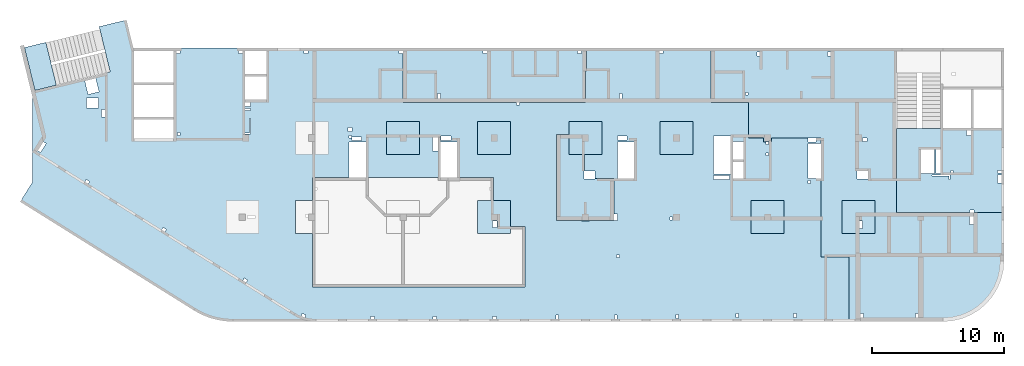
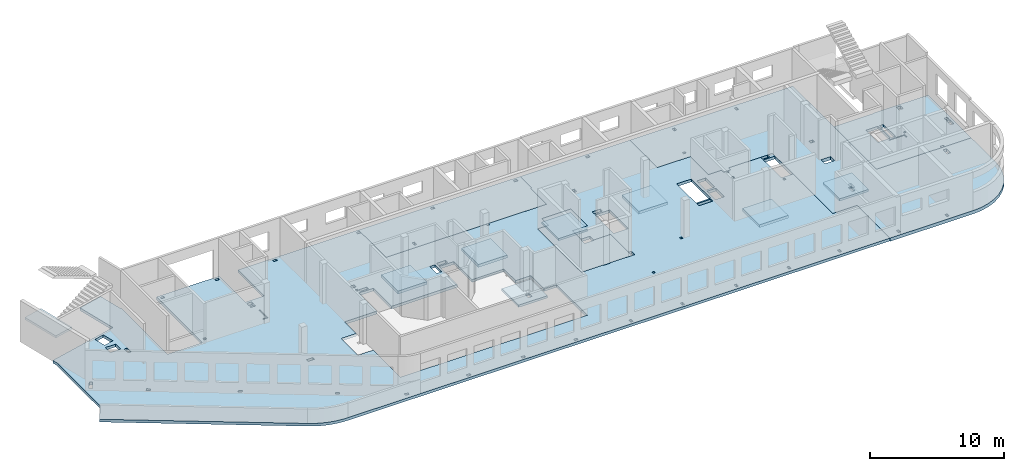
# One storey, part 2 of 10: 13 slabs.
"""IFC4 building model written with IfcOpenShell, lengths in millimetres."""

from ifc_helpers import new_model, entity, si_unit, converted_unit, derived_unit, direction, frame, origin, place, context, subcontext, project, spatial, indexed_curve, outline, extrude, material, type_object, element, save


model = new_model("IFC4")

# Units and contexts
model_context = context("Model", 3, precision=0.01, world=origin(), true_north=direction((6.12303176911189e-17, 1.0)))
plan_context = context("Plan", 3, precision=0.01, world=origin(), true_north=direction((6.12303176911189e-17, 1.0)))
body_context = subcontext(model_context, "Body", "Model", "MODEL_VIEW")
ifc_project = project(units=[si_unit("LENGTHUNIT", "METRE", prefix="MILLI"), si_unit("AREAUNIT", "SQUARE_METRE"), si_unit("VOLUMEUNIT", "CUBIC_METRE"), converted_unit("PLANEANGLEUNIT", "DEGREE", entity("IfcRatioMeasure", 0.0174532925199433), si_unit("PLANEANGLEUNIT", "RADIAN"), dimensions=[0, 0, 0, 0, 0, 0, 0]), si_unit("MASSUNIT", "GRAM", prefix="KILO"), derived_unit("MASSDENSITYUNIT", [(si_unit("MASSUNIT", "GRAM", prefix="KILO"), 1), (si_unit("LENGTHUNIT", "METRE"), -3)]), derived_unit("MOMENTOFINERTIAUNIT", [(si_unit("LENGTHUNIT", "METRE"), 4)]), si_unit("TIMEUNIT", "SECOND"), si_unit("FREQUENCYUNIT", "HERTZ"), si_unit("THERMODYNAMICTEMPERATUREUNIT", "DEGREE_CELSIUS"), derived_unit("THERMALTRANSMITTANCEUNIT", [(si_unit("MASSUNIT", "GRAM", prefix="KILO"), 1), (si_unit("THERMODYNAMICTEMPERATUREUNIT", "KELVIN"), -1), (si_unit("TIMEUNIT", "SECOND"), -3)]), derived_unit("VOLUMETRICFLOWRATEUNIT", [(si_unit("LENGTHUNIT", "METRE"), 3), (si_unit("TIMEUNIT", "SECOND"), -1)]), derived_unit("MASSFLOWRATEUNIT", [(si_unit("MASSUNIT", "GRAM", prefix="KILO"), 1), (si_unit("TIMEUNIT", "SECOND"), -1)]), derived_unit("ROTATIONALFREQUENCYUNIT", [(si_unit("TIMEUNIT", "SECOND"), -1)]), si_unit("ELECTRICCURRENTUNIT", "AMPERE"), si_unit("ELECTRICVOLTAGEUNIT", "VOLT"), si_unit("POWERUNIT", "WATT"), si_unit("FORCEUNIT", "NEWTON", prefix="KILO"), si_unit("ILLUMINANCEUNIT", "LUX"), si_unit("LUMINOUSFLUXUNIT", "LUMEN"), si_unit("LUMINOUSINTENSITYUNIT", "CANDELA"), derived_unit("USERDEFINED", [(si_unit("MASSUNIT", "GRAM", prefix="KILO"), -1), (si_unit("LENGTHUNIT", "METRE"), -2), (si_unit("TIMEUNIT", "SECOND"), 3), (si_unit("LUMINOUSFLUXUNIT", "LUMEN"), 1)]), derived_unit("LINEARVELOCITYUNIT", [(si_unit("LENGTHUNIT", "METRE"), 1), (si_unit("TIMEUNIT", "SECOND"), -1)]), si_unit("PRESSUREUNIT", "PASCAL"), derived_unit("USERDEFINED", [(si_unit("LENGTHUNIT", "METRE"), -2), (si_unit("MASSUNIT", "GRAM", prefix="KILO"), 1), (si_unit("TIMEUNIT", "SECOND"), -2)]), derived_unit("LINEARFORCEUNIT", [(si_unit("MASSUNIT", "GRAM", prefix="KILO"), 1), (si_unit("LENGTHUNIT", "METRE"), 1), (si_unit("TIMEUNIT", "SECOND"), -2), (si_unit("LENGTHUNIT", "METRE"), -1)]), derived_unit("PLANARFORCEUNIT", [(si_unit("MASSUNIT", "GRAM", prefix="KILO"), 1), (si_unit("LENGTHUNIT", "METRE"), 1), (si_unit("TIMEUNIT", "SECOND"), -2), (si_unit("LENGTHUNIT", "METRE"), -2)])], contexts=[model_context, plan_context])

# Site, building, storey
site_placement = place(None, origin())
site = spatial("IfcSite", under=ifc_project, at=site_placement, CompositionType="ELEMENT")
building_placement = place(site_placement, origin())
building = spatial("IfcBuilding", under=site, at=building_placement, CompositionType="ELEMENT")
storey_placement = place(building_placement, frame((0.0, 0.0, 4200.0)))
storey = spatial("IfcBuildingStorey", under=building, at=storey_placement, Name="02", CompositionType="ELEMENT", Elevation=4200.0)

# Slabs
ifc_material = material()
slab_type_1 = type_object("IfcSlabType", Name=":ADSK_ 25_250", PredefinedType="FLOOR", material=ifc_material)
placement = place(storey_placement, origin())
element("IfcSlab", 1, at=placement, inside=storey, type_object=slab_type_1, material=ifc_material, Name=":ADSK_ 25_250", ObjectType=":ADSK_ 25_250", PredefinedType="FLOOR", context=body_context, shape_type="SweptSolid", body=[
    extrude(outline(indexed_curve([(-6148.863810471, 19959.387129888), (-6148.86381047096, 14559.387129888), (-2248.86381047095, 14559.387129888), (-2248.86381047095, 12934.387129888), (-6148.86381047096, 12934.387129888), (-6148.86381047092, 2589.38712988804), (-5948.86381047095, 2589.38712988804), (-5948.86381047095, 2889.3871298881), (-5748.86381047108, 2889.3871298881), (-5748.86381047108, 2589.38712988803), (-2048.86381047092, 2589.38712988804), (-2048.86381047089, -6010.61287011193), (-1848.86381047108, -6010.61287011193), (-1848.86381047108, -6210.61287011191), (-2048.86381047089, -6210.61287011191), (-2048.86381047088, -11210.612870112), (-4428.86381047078, -11210.612870112), (-4428.86381047078, -11310.612870112), (-6148.86381047087, -11310.612870112), (-6148.86381047084, -20730.6128701121), (-2048.86381047081, -20730.6128701119), (-2048.86381047066, -23560.6128701121), (651.136189529272, -23560.612870112), (651.136189529332, -24710.612870112), (951.136189529167, -24710.612870112), (951.136189529167, -24885.6128701119), (1151.13618952893, -24885.6128701119), (1151.13618952893, -25085.6128701119), (951.136189529167, -25085.6128701119), (951.136189529167, -25310.612870112), (651.13618952933, -25310.612870112), (651.136189529339, -28070.6128701119), (936.136189528923, -28070.6128701119), (936.136189528923, -28670.612870112), (651.136189529343, -28670.612870112), (651.136189529343, -29070.6128701119), (1056.13618952891, -29070.6128701119), (1056.13618952891, -28070.6128701119), (3726.13618952934, -28070.6128701119), (3726.13618952934, -29070.6128701119), (9651.13618952933, -29070.6128701119), (9651.13618952934, -31160.6128701119), (14551.1361895292, -31160.6128701119), (14551.1361895291, 15459.3871298881), (14542.4813688931, 15770.6090526414), (14516.5436590997, 16080.8689861379), (14473.4032338008, 16389.2079146363), (14413.1934403692, 16694.6727602364), (14336.1003877199, 16996.319328849), (14242.362371047, 17293.2152287074), (14132.2691352507, 17584.4427523971), (14006.1609793344, 17869.1017134961), (13864.4277045374, 18146.3122290575), (13707.5074094566, 18415.2174393349), (13700.2568944495, 18427.3871298935), (5483.13618952893, 31577.7857668567), (4013.36245521472, 30659.3871298881), (-2487.98081248951, 30659.387129888), (-2877.35012792884, 30754.3000199726), (-4338.56524356843, 24759.8315259752), (-7777.85952938926, 25598.1958951609), (-8282.29910745868, 23528.7900113196), (-6148.86381047102, 23008.7425863779), (-6148.86381047102, 22959.387129888), (701.136189528992, 22959.387129888), (701.136189529, 19959.387129888), (-6148.863810471, 19959.387129888)], self_intersect=False), holes=[indexed_curve([(5401.13618952907, 10739.3871298881), (6651.13618952907, 10739.3871298881), (7901.13618952907, 10739.3871298881), (7901.13618952906, 9439.38712988806), (11951.1361895291, 9439.38712988807), (11951.1361895292, -6635.6128701119), (7351.13618952919, -6635.61287011193), (7351.13618952918, -5560.61287011193), (6651.13618952918, -5560.61287011194), (5401.13618952913, -5560.61287011194), (5401.13618952912, -4310.61287011194), (5401.13618952912, -4260.61287011193), (3661.13618952913, -4260.61287011194), (3661.13618952912, -1510.61287011193), (951.13541588538, -1510.61287011193), (951.13541588538, -240.612870111946), (3661.13618952912, -240.612870111946), (3661.1361895291, 5409.38712988806), (951.13618952892, 5409.38712988806), (951.13618952892, 6669.38712988807), (3661.1361895291, 6669.38712988807), (3661.13618952909, 9439.38712988805), (5401.13618952906, 9439.38712988806), (5401.13618952907, 9489.38712988806), (5401.13618952907, 10739.3871298881)], self_intersect=False), indexed_curve([(401.136189529216, -9035.61287011196), (6651.1361895292, -9035.61287011194), (6901.1361895292, -9035.61287011194), (6901.1361895292, -10910.6128701119), (6951.1361895292, -10910.6128701119), (6951.1361895292, -11210.612870112), (6951.1361895292, -11510.612870112), (6901.1361895292, -11510.612870112), (6901.13618952895, -13385.612870112), (6901.13618952892, -13635.6128701119), (6401.13618952891, -13635.6128701119), (6401.13618952891, -13385.612870112), (3726.13618952915, -13385.612870112), (3726.13618952916, -11925.6128701119), (3166.13618952922, -11925.6128701119), (3166.13618952922, -11160.612870112), (1901.13618952915, -11160.612870112), (1901.13618952915, -12460.6128701119), (-598.863810470838, -12460.6128701119), (-598.863810470847, -9960.61287011195), (401.136189529218, -9960.61287011195), (401.136189529216, -9035.61287011196)], self_intersect=False), indexed_curve([(-2358.86381047109, 25649.3871298881), (-2358.86381047109, 26549.3871298881), (-1618.86381047108, 26549.3871298881), (-1618.86381047108, 25649.3871298881), (-2358.86381047109, 25649.3871298881)], self_intersect=False), indexed_curve([(-2845.01874476109, 25608.8640213711), (-3865.14975025251, 25857.5257884124), (-3663.85616990531, 26683.347133808), (-2643.72394620801, 26434.6903645437), (-2845.01874476109, 25608.8640213711)], self_intersect=False), indexed_curve([(1070.04881669485, 29610.0494864465), (937.569000669967, 29822.0615105065), (1616.01119569202, 30245.9909716361), (1748.48729366069, 30033.9848977099), (1070.04881669485, 29610.0494864465)], self_intersect=False), indexed_curve([(4124.42832046992, 26420.8069499175), (3954.6315026398, 26314.7081930707), (3795.65795471008, 26569.1240162138), (3965.4547725402, 26675.2227730606), (4124.42832046992, 26420.8069499175)], self_intersect=False), indexed_curve([(7754.32433139231, 20611.6456550412), (7584.52751356219, 20505.5468981944), (7425.55396563247, 20759.9627213374), (7595.35078346259, 20866.0614781842), (7754.32433139231, 20611.6456550412)], self_intersect=False), indexed_curve([(11594.4873180832, 14465.9802913018), (11424.690500253, 14359.881534455), (11265.7169523233, 14614.2973575981), (11435.5137701534, 14720.3961144449), (11594.4873180832, 14465.9802913018)], self_intersect=False), indexed_curve([(14046.0691106705, 9954.81624003096), (13949.2127758848, 10238.7508282936), (14137.123442309, 10302.851290757), (14233.9797770947, 10018.9167024943), (14046.0691106705, 9954.81624003096)], self_intersect=False), indexed_curve([(14151.1361895289, 4739.38712988809), (14151.1361895289, 5039.38712988809), (14351.1361895291, 5039.38712988809), (14351.1361895291, 4739.38712988809), (14151.1361895289, 4739.38712988809)], self_intersect=False), indexed_curve([(14151.1361895289, 339.387129888087), (14351.1361895289, 339.387129888087), (14351.1361895289, 39.3871298880856), (14151.1361895289, 39.3871298880856), (14151.1361895289, 339.387129888087)], self_intersect=False), indexed_curve([(14151.1361895289, -4470.61287011193), (14151.1361895289, -4170.61287011193), (14351.1361895292, -4170.61287011193), (14351.1361895292, -4470.61287011193), (14151.1361895289, -4470.61287011193)], self_intersect=False), indexed_curve([(14051.1361895289, -9185.61287011191), (14051.1361895289, -8985.61287011193), (14351.1361895292, -8985.61287011193), (14351.1361895292, -9185.61287011191), (14051.1361895289, -9185.61287011191)], self_intersect=False), indexed_curve([(14051.1361895289, -13610.6128701119), (14051.1361895289, -13410.6128701119), (14351.1361895289, -13410.6128701119), (14351.1361895289, -13610.6128701119), (14051.1361895289, -13610.6128701119)], self_intersect=False), indexed_curve([(14001.1361895289, -18260.6128701119), (14001.1361895289, -18060.6128701119), (14301.1361895289, -18060.6128701119), (14301.1361895289, -18260.6128701119), (14001.1361895289, -18260.6128701119)], self_intersect=False), indexed_curve([(13951.1361895289, -22810.6128701119), (13951.1361895289, -22610.6128701119), (14251.1361895289, -22610.6128701119), (14251.1361895289, -22810.6128701119), (13951.1361895289, -22810.6128701119)], self_intersect=False), indexed_curve([(13951.1361895289, -27185.6128701119), (13951.1361895289, -26985.6128701119), (14251.1361895289, -26985.6128701119), (14251.1361895289, -27185.6128701119), (13951.1361895289, -27185.6128701119)], self_intersect=False), indexed_curve([(4086.13618952892, -28070.6128701119), (4086.13618952892, -28270.6128701119), (3886.13618952891, -28270.6128701119), (3886.13618952891, -28070.6128701119), (4086.13618952892, -28070.6128701119)], self_intersect=False), indexed_curve([(-5948.86381047099, 15059.3871298881), (-5748.86381047108, 15059.3871298881), (-5748.86381047108, 14759.387129888), (-5948.86381047099, 14759.387129888), (-5948.86381047099, 15059.3871298881)], self_intersect=False), indexed_curve([(251.136189528923, 19459.3871298881), (251.136189528923, 19659.3871298881), (451.136189528912, 19659.3871298881), (451.136189528912, 19459.3871298881), (251.136189528923, 19459.3871298881)], self_intersect=False), indexed_curve([(-1748.86381047109, 14559.387129888), (-1748.86381047109, 14129.3871298881), (-2048.86381047076, 14129.3871298881), (-2048.86381047076, 14559.387129888), (-1748.86381047109, 14559.387129888)], self_intersect=False), indexed_curve([(-1438.86381047107, 14559.3871298881), (-1438.86381047107, 14129.3871298881), (-1596.25793295049, 14129.3871298881), (-1596.25793295049, 14559.3871298881), (-1438.86381047107, 14559.3871298881)], self_intersect=False), indexed_curve([(271.136189528919, 14549.3871298881), (351.136189529037, 14549.3871298881), (351.136189529039, 14159.387129888), (351.136189529039, 14129.3871298881), (-838.863810471089, 14129.3871298881), (-838.863810471089, 14209.3871298881), (271.136189528921, 14209.3871298881), (271.136189528919, 14549.3871298881)], self_intersect=False), indexed_curve([(6501.13618952892, 13809.3871298881), (6501.13618952892, 14369.3871298881), (6751.13618952892, 14369.3871298881), (6751.13618952892, 13809.3871298881), (6501.13618952892, 13809.3871298881)], self_intersect=False), indexed_curve([(-148.86381047109, 6439.38712988809), (-148.86381047109, 6739.38712988809), (151.136189528911, 6739.38712988809), (151.136189528911, 6439.38712988809), (-148.86381047109, 6439.38712988809)], self_intersect=False), indexed_curve([(451.136189528912, 6489.38712988807), (451.136189528912, 6689.3871298881), (651.136189529096, 6689.3871298881), (651.136189529096, 6489.38712988807), (451.136189528912, 6489.38712988807)], self_intersect=False), indexed_curve([(831.136189528913, 6449.38712988808), (831.136189528913, 5739.38712988807), (581.136189528917, 5739.38712988807), (581.136189528917, 6449.38712988808), (831.136189528913, 6449.38712988808)], self_intersect=False), indexed_curve([(601.136189529084, 369.387398442862), (1641.13618952892, 369.387398442862), (1641.13618952892, -90.6128701119455), (601.136189529084, -90.6128701119455), (601.136189529084, 369.387398442862)], self_intersect=False), indexed_curve([(511.135415885374, -1050.61287011191), (511.135415885374, -270.61260155714), (831.136189528913, -270.61260155714), (831.136189528913, -1050.61287011191), (511.135415885374, -1050.61287011191)], self_intersect=False), indexed_curve([(511.136189528916, -14370.6128701119), (511.136189528916, -13650.6128701119), (801.136189528919, -13650.6128701119), (801.136189528919, -14370.6128701119), (511.136189528916, -14370.6128701119)], self_intersect=False), indexed_curve([(951.13618952892, -14910.6128701119), (951.13618952892, -13650.6128701119), (3726.13618952925, -13650.6128701119), (3726.13618952925, -14910.6128701119), (951.13618952892, -14910.6128701119)], self_intersect=False), indexed_curve([(3796.13618952891, -22140.6128701119), (3496.13618952891, -22140.6128701119), (3496.13618952891, -20930.6128701119), (3796.13618952891, -20930.6128701119), (3796.13618952891, -22140.6128701119)], self_intersect=False), indexed_curve([(2476.13618952915, -23170.6128701119), (2476.13618952915, -22390.6128701119), (3726.13618952917, -22390.6128701119), (3726.13618952917, -23170.6128701119), (2476.13618952915, -23170.6128701119)], self_intersect=False), indexed_curve([(926.136189528926, -23170.6128701119), (926.136189528926, -22390.6128701119), (2276.13618952915, -22390.6128701119), (2276.13618952915, -23170.6128701119), (926.136189528926, -23170.6128701119)], self_intersect=False), indexed_curve([(3376.13618952892, -22190.6128701119), (516.136189528915, -22190.6128701119), (516.136189528915, -20930.6128701119), (3376.13618952892, -20930.6128701119), (3376.13618952892, -22190.6128701119)], self_intersect=False), indexed_curve([(1771.13618952892, -25085.6128701119), (1771.13618952892, -24885.6128701119), (1971.13618952891, -24885.6128701119), (1971.13618952891, -25085.6128701119), (1771.13618952892, -25085.6128701119)], self_intersect=False), indexed_curve([(6851.13618952891, -17810.6128701119), (6651.13618952926, -17810.6128701119), (6651.13618952926, -17610.6128701119), (6851.13618952891, -17610.6128701119), (6851.13618952891, -17810.6128701119)], self_intersect=False), indexed_curve([(-5948.86381047089, -17110.6128701119), (-5948.86381047089, -16810.6128701119), (-5748.86381047108, -16810.6128701119), (-5748.86381047108, -17110.6128701119), (-5948.86381047089, -17110.6128701119)], self_intersect=False), indexed_curve([(-5948.86381047109, 9789.38712988809), (-5948.86381047109, 10089.3871298881), (-5748.86381047108, 10089.3871298881), (-5748.86381047108, 9789.38712988809), (-5948.86381047109, 9789.38712988809)], self_intersect=False), indexed_curve([(-5948.86381047101, 19459.3871298881), (-5948.86381047101, 19759.387129888), (-5748.86381047108, 19759.387129888), (-5748.86381047108, 19459.3871298881), (-5948.86381047101, 19459.3871298881)], self_intersect=False), indexed_curve([(-938.863810471084, 25159.387129888), (-1498.86381047108, 25159.387129888), (-1498.86381047108, 25409.3871298881), (-938.863810471084, 25409.3871298881), (-938.863810471084, 25159.387129888)], self_intersect=False), indexed_curve([(-2708.86381047108, -13980.6128701119), (-2708.86381047108, -13780.6128701119), (-2348.86381047107, -13780.6128701119), (-2348.86381047107, -13980.6128701119), (-2708.86381047108, -13980.6128701119)], self_intersect=False), indexed_curve([(9701.13618952892, -13780.6128701119), (9501.13618952892, -13780.6128701119), (9501.13618952892, -13580.6128701119), (9701.13618952892, -13580.6128701119), (9701.13618952892, -13780.6128701119)], self_intersect=False)]), frame((30659.39, 14351.14, -400.0), z_axis=(0.0, 0.0, -1.0), x_axis=(0.0, -1.0, 0.0)), (0.0, 0.0, -1.0), 250.0),
])
slab_type_2 = type_object("IfcSlabType", Name=":ADSK_ 25_300", PredefinedType="FLOOR", material=ifc_material)
element("IfcSlab", 2, at=placement, inside=storey, type_object=slab_type_2, material=ifc_material, Name=":ADSK_ 25_300", ObjectType=":ADSK_ 25_300", PredefinedType="FLOOR", context=body_context, shape_type="SweptSolid", body=[
    extrude(outline(indexed_curve([(-10063.7142857141, -4642.89201240349), (-10063.7142857141, -8742.89201240353), (3976.28571428571, -8742.89201240353), (3976.28571428572, 3707.10798759665), (12116.2857142857, 3707.10798759665), (12116.2857142857, 7357.10798759648), (12059.6520810234, 8076.70652678149), (11891.1456892434, 8778.58616172119), (11614.9157255522, 9445.46428639835), (11237.7638884105, 10060.9201481418), (10768.9769077439, 10609.7991810546), (10220.0978748311, 11078.5861617212), (9604.64201308768, 11455.7379988629), (8937.76388841052, 11731.9679625542), (8235.88425347083, 11900.4743543341), (7516.28571428577, 11957.1079875965), (366.285714285737, 11957.1079875965), (366.285714285731, 7057.10798759662), (-1723.71428571428, 7057.10798759662), (-1723.71428571429, -1942.89201240337), (-5483.71428571427, -1942.89201240337), (-5483.71428571427, -1642.89201240353), (-6083.71428571429, -1642.89201240353), (-6083.71428571429, -1942.89201240342), (-7233.71428571415, -1942.89201240342), (-7233.71428571415, -4642.89201240349), (-10063.7142857141, -4642.89201240349)], self_intersect=False), holes=[indexed_curve([(1466.28571428572, 11357.1079875962), (1266.28571428573, 11357.1079875962), (1266.28571428573, 11657.1079875956), (1466.28571428572, 11657.1079875956), (1466.28571428572, 11357.1079875962)], self_intersect=False), indexed_curve([(5616.28571428573, 11357.1079875962), (5416.28571428572, 11357.1079875962), (5416.28571428572, 11657.1079875965), (5616.28571428573, 11657.1079875965), (5616.28571428573, 11357.1079875962)], self_intersect=False), indexed_curve([(9821.28571428571, 4617.10798759617), (9821.28571428571, 4007.10798759665), (9521.28571428568, 4007.10798759665), (9521.28571428569, 4617.10798759617), (9821.28571428571, 4617.10798759617)], self_intersect=False), indexed_curve([(1001.28571428567, 572.107213952653), (1001.28571428567, 1172.1079875962), (1831.28571428573, 1172.1079875962), (1831.28571428572, 572.107213952651), (1001.28571428567, 572.107213952653)], self_intersect=False), indexed_curve([(1416.2857142857, -1692.89201240381), (1736.28571428565, -1692.89201240381), (1736.28571428565, -1942.89201240336), (1416.2857142857, -1942.89201240336), (1416.2857142857, -1692.89201240381)], self_intersect=False), indexed_curve([(-1033.71428571429, -8142.89201240379), (-1033.71428571429, -8442.89201240379), (-1233.71428571435, -8442.89201240379), (-1233.71428571435, -8142.89201240379), (-1033.71428571429, -8142.89201240379)], self_intersect=False), indexed_curve([(-6383.7142857143, -8142.89201240375), (-6383.7142857143, -8442.89201240376), (-6583.71428571435, -8442.89201240375), (-6583.71428571435, -8142.89201240375), (-6383.7142857143, -8142.89201240375)], self_intersect=False), indexed_curve([(-7463.71428571432, -5192.89201240378), (-7263.71428571432, -5192.89201240378), (-7263.71428571432, -5392.89201240377), (-7463.71428571432, -5392.89201240377), (-7463.71428571432, -5192.89201240378)], self_intersect=False), indexed_curve([(1166.28571428572, 4917.1079875962), (1416.28571428568, 4917.1079875962), (1416.28571428567, 4357.1079875962), (1166.28571428571, 4357.10798759621), (1166.28571428572, 4917.1079875962)], self_intersect=False)]), frame((61453.71, 11757.11, -450.0), z_axis=(0.0, 0.0, -1.0), x_axis=(1.0, 0.0, 0.0)), (0.0, 0.0, -1.0), 300.0),
])
slab_type_3 = type_object("IfcSlabType", Name=":ADSK_ 25_250", PredefinedType="FLOOR", material=ifc_material)
element("IfcSlab", 3, at=placement, inside=storey, type_object=slab_type_3, material=ifc_material, Name=":ADSK_ 25_250", ObjectType=":ADSK_ 25_250", PredefinedType="FLOOR", context=body_context, shape_type="SweptSolid", body=[
    extrude(outline(indexed_curve([(-3734.28571428571, -3699.46019902423), (-3534.28571428573, -3699.46019902423), (1065.71428571429, -3699.46019902424), (1065.71428571429, -3659.46019902427), (4405.71428571427, -3659.46019902428), (4405.71428571427, -213.238805853918), (4405.71428571428, -13.2388058539183), (4405.71428571428, 2720.5398009757), (-1154.28571428569, 2720.53980097572), (-1154.28571428569, 2520.53980097523), (-1454.2857142857, 2520.53980097523), (-1454.2857142857, 2720.53980097572), (-3534.28571428572, 2720.53980097573), (-3734.28571428571, 2720.53980097573), (-3734.28571428571, -3699.46019902423)], self_intersect=False), holes=[indexed_curve([(-3534.28571428572, -114.460199024756), (-3534.28571428572, 485.539800975246), (-3234.28571428571, 485.539800975246), (-3234.28571428571, -114.460199024756), (-3534.28571428572, -114.460199024756)], self_intersect=False), indexed_curve([(-3534.28571428571, -479.460199024759), (-3534.28571428571, -279.460199024753), (-3234.28571428571, -279.460199024753), (-3234.28571428571, -479.460199024759), (-3534.28571428571, -479.460199024759)], self_intersect=False), indexed_curve([(-1234.28571428573, -3099.46019902475), (-884.285714285686, -3099.46019902475), (-884.285714285686, -3499.46019902425), (-1234.28571428573, -3499.46019902425), (-1234.28571428573, -3099.46019902475)], self_intersect=False), indexed_curve([(1395.71428571435, -2059.46019902427), (1065.71428571427, -2059.46019902427), (1065.71428571427, -254.460199024759), (1395.71428571435, -254.460199024759), (1395.71428571435, -2059.46019902427)], self_intersect=False), indexed_curve([(2555.71428571428, -254.460199024759), (2555.71428571428, -2059.46019902429), (1515.71428571432, -2059.46019902429), (1515.71428571432, -254.460199024759), (2555.71428571428, -254.460199024759)], self_intersect=False), indexed_curve([(115.714285714398, -464.460199024745), (115.714285714398, -314.460199024745), (265.714285714399, -314.460199024745), (265.714285714399, -464.460199024745), (115.714285714398, -464.460199024745)], self_intersect=False), indexed_curve([(435.714285714291, -54.4601990247521), (1735.71428571431, -54.4601990247564), (1735.71428571431, -114.460199024258), (355.714285714309, -114.460199024253), (355.714285714309, 205.539800975241), (435.714285714291, 205.539800975241), (435.714285714291, -54.4601990247521)], self_intersect=False)]), frame((69835.71, 10770.54, -400.0), z_axis=(0.0, 0.0, 1.0), x_axis=(-1.0, 0.0, 0.0)), (0.0, 0.0, 1.0), 250.0),
])
slab_type_4 = type_object("IfcSlabType", Name=":ADSK_ 25_300", PredefinedType="FLOOR", material=ifc_material)
element("IfcSlab", 4, at=placement, inside=storey, type_object=slab_type_4, material=ifc_material, Name=":ADSK_ 25_300", ObjectType=":ADSK_ 25_300", PredefinedType="FLOOR", context=body_context, shape_type="SweptSolid", body=[
    extrude(outline(indexed_curve([(-1876.36363636365, -7881.81818181818), (-1676.36363636369, -7881.81818181818), (-1476.36363636382, -7881.81818181818), (2223.63636363634, -7881.81818181818), (2223.63636363637, 718.181818181788), (2223.63636363637, 918.181818181777), (2223.63636363639, 5918.18181818182), (-156.363636363512, 5918.18181818182), (-156.363636363512, 6018.18181818182), (-1676.36363636364, 6018.18181818182), (-1876.36363636361, 6018.18181818182), (-1876.36363636365, -7881.81818181818)], self_intersect=False), holes=[indexed_curve([(-1676.36363636367, -1831.81818181822), (-1676.36363636367, -1531.81818181818), (-1476.36363636382, -1531.81818181818), (-1476.36363636382, -1831.81818181822), (-1676.36363636367, -1831.81818181822)], self_intersect=False), indexed_curve([(-1676.36363636382, 5618.18181818178), (-1476.36363636382, 5618.18181818178), (-1476.36363636382, 5318.18181818178), (-1676.36363636382, 5318.18181818178), (-1676.36363636382, 5618.18181818178)], self_intersect=False), indexed_curve([(1563.63636363615, -5261.8181818182), (1563.63636363615, -5061.81818181821), (1923.63636363656, -5061.81818181821), (1923.63636363656, -5261.8181818182), (1563.63636363615, -5261.8181818182)], self_intersect=False)]), frame((35951.82, 18623.64, -450.0), z_axis=(0.0, 0.0, 1.0), x_axis=(0.0, -1.0, 0.0)), (0.0, 0.0, 1.0), 300.0),
])
slab_type_5 = type_object("IfcSlabType", Name=":ADSK_ 25_200", PredefinedType="FLOOR", material=ifc_material)
element("IfcSlab", 5, at=placement, inside=storey, type_object=slab_type_5, material=ifc_material, Name=":ADSK_ 25_200", ObjectType=":ADSK_ 25_200", PredefinedType="FLOOR", context=body_context, shape_type="SweptSolid", body=[
    extrude(outline(indexed_curve([(-1250.0, -1250.0), (1250.0, -1250.0), (1250.0, 1250.0), (-1250.0, 1250.0), (-1250.0, -1250.0)], self_intersect=False), holes=[indexed_curve([(-199.999999999994, 299.999999999822), (-199.999999999994, 759.999999999822), (120.000000000007, 759.999999999822), (120.000000000007, 299.999999999822), (-199.999999999994, 299.999999999822)], self_intersect=False)]), frame((34970.0, 7700.0, -650.0), z_axis=(0.0, 0.0, 1.0), x_axis=(-1.0, 0.0, 0.0)), (0.0, 0.0, 1.0), 200.0),
])
slab_type_6 = type_object("IfcSlabType", Name=":ADSK_ 25_250", PredefinedType="FLOOR", material=ifc_material)
element("IfcSlab", 6, at=placement, inside=storey, type_object=slab_type_6, material=ifc_material, Name=":ADSK_ 25_250", ObjectType=":ADSK_ 25_250", PredefinedType="FLOOR", context=body_context, shape_type="SweptSolid", body=[
    extrude(outline(indexed_curve([(-1250.0, -1250.0), (1250.0, -1250.0), (1250.0, 1250.0), (-1250.0, 1250.0), (-1250.0, -1250.0)], self_intersect=False)), frame((28070.0, 13700.0, -400.0), z_axis=(0.0, 0.0, -1.0), x_axis=(0.0, 1.0, 0.0)), (0.0, 0.0, 1.0), 250.0),
])
slab_type_7 = type_object("IfcSlabType", Name=":ADSK_ 25_250", PredefinedType="FLOOR", material=ifc_material)
element("IfcSlab", 7, at=placement, inside=storey, type_object=slab_type_7, material=ifc_material, Name=":ADSK_ 25_250", ObjectType=":ADSK_ 25_250", PredefinedType="FLOOR", context=body_context, shape_type="SweptSolid", body=[
    extrude(outline(indexed_curve([(-1250.0, -1250.0), (1250.0, -1250.0), (1250.0, 1250.0), (-1250.0, 1250.0), (-1250.0, -1250.0)], self_intersect=False)), frame((34970.0, 13700.0, -400.0), z_axis=(0.0, 0.0, -1.0), x_axis=(0.0, 1.0, 0.0)), (0.0, 0.0, 1.0), 250.0),
])
slab_type_8 = type_object("IfcSlabType", Name=":ADSK_ 25_200", PredefinedType="FLOOR", material=ifc_material)
element("IfcSlab", 8, at=placement, inside=storey, type_object=slab_type_8, material=ifc_material, Name=":ADSK_ 25_200", ObjectType=":ADSK_ 25_200", PredefinedType="FLOOR", context=body_context, shape_type="SweptSolid", body=[
    extrude(outline(indexed_curve([(-1250.0, -1250.0), (1250.0, -1250.0), (1250.0, 1250.0), (-1250.0, 1250.0), (-1250.0, -1250.0)], self_intersect=False)), frame((41870.0, 13700.0, -450.0), z_axis=(0.0, 0.0, -1.0), x_axis=(0.0, 1.0, 0.0)), (0.0, 0.0, 1.0), 200.0),
])
slab_type_9 = type_object("IfcSlabType", Name=":ADSK_ 25_300", PredefinedType="FLOOR", material=ifc_material)
element("IfcSlab", 9, at=placement, inside=storey, type_object=slab_type_9, material=ifc_material, Name=":ADSK_ 25_300", ObjectType=":ADSK_ 25_300", PredefinedType="FLOOR", context=body_context, shape_type="SweptSolid", body=[
    extrude(outline(indexed_curve([(-3221.66666666668, -2238.88888888889), (3278.33333333331, -2238.88888888889), (3278.33333333331, -1313.8888888889), (4278.33333333337, -1313.8888888889), (4278.33333333337, 1186.1111111111), (1778.33333333338, 1186.1111111111), (1778.33333333338, -113.888888888894), (513.333333333305, -113.888888888893), (513.333333333305, -153.888888888892), (-86.6666666666948, -153.888888888891), (-86.6666666666959, 651.111111111108), (-46.666666666614, 651.111111111107), (-46.6666666666164, 2111.11111111116), (-3221.66666666668, 2111.11111111115), (-3221.66666666667, 236.111111111154), (-3271.66666666667, 236.111111111154), (-3271.66666666667, -363.8888888889), (-3221.66666666668, -363.8888888889), (-3221.66666666668, -2238.88888888889)], self_intersect=False)), frame((41933.89, 10671.67, -150.0), z_axis=(0.0, 0.0, -1.0), x_axis=(0.0, 1.0, 0.0)), (0.0, 0.0, 1.0), 300.0),
])
slab_type_10 = type_object("IfcSlabType", Name=":ADSK_ 25_250", PredefinedType="FLOOR", material=ifc_material)
element("IfcSlab", 10, at=placement, inside=storey, type_object=slab_type_10, material=ifc_material, Name=":ADSK_ 25_250", ObjectType=":ADSK_ 25_250", PredefinedType="FLOOR", context=body_context, shape_type="SweptSolid", body=[
    extrude(outline(indexed_curve([(-1250.0, -1250.0), (1250.0, -1250.0), (1250.0, 1249.99999999999), (-1250.0, 1249.99999999999), (-1250.0, -1250.0)], self_intersect=False)), frame((48770.0, 13700.0, -400.0), z_axis=(0.0, 0.0, -1.0), x_axis=(0.0, 1.0, 0.0)), (0.0, 0.0, 1.0), 250.0),
])
slab_type_11 = type_object("IfcSlabType", Name=":ADSK_ 25_250", PredefinedType="FLOOR", material=ifc_material)
element("IfcSlab", 11, at=placement, inside=storey, type_object=slab_type_11, material=ifc_material, Name=":ADSK_ 25_250", ObjectType=":ADSK_ 25_250", PredefinedType="FLOOR", context=body_context, shape_type="SweptSolid", body=[
    extrude(outline(indexed_curve([(-1250.0, -1249.99999999999), (1250.0, -1249.99999999999), (1250.0, 1250.0), (-1250.0, 1250.0), (-1250.0, -1249.99999999999)], self_intersect=False)), frame((55670.0, 7700.0, -400.0), z_axis=(0.0, 0.0, -1.0), x_axis=(0.0, 1.0, 0.0)), (0.0, 0.0, 1.0), 250.0),
])
slab_type_12 = type_object("IfcSlabType", Name=":ADSK_ 25_200", PredefinedType="FLOOR", material=ifc_material)
element("IfcSlab", 12, at=placement, inside=storey, type_object=slab_type_12, material=ifc_material, Name=":ADSK_ 25_200", ObjectType=":ADSK_ 25_200", PredefinedType="FLOOR", context=body_context, shape_type="SweptSolid", body=[
    extrude(outline(indexed_curve([(-1250.00000000001, -1250.0), (1249.99999999999, -1250.0), (1249.99999999999, 1250.0), (-1250.00000000001, 1250.0), (-1250.00000000001, -1250.0)], self_intersect=False), holes=[indexed_curve([(-50.000000000006, 859.999999999729), (-50.000000000006, 299.999999999735), (-299.999999999966, 299.999999999735), (-299.999999999966, 859.999999999729), (-50.000000000006, 859.999999999729)], self_intersect=False)]), frame((62570.0, 7700.0, -650.0), z_axis=(0.0, 0.0, 1.0), x_axis=(-1.0, 0.0, 0.0)), (0.0, 0.0, 1.0), 200.0),
])
slab_type_13 = type_object("IfcSlabType", Name=":ADSK_ 25_200", PredefinedType="FLOOR", material=ifc_material)
element("IfcSlab", 13, at=placement, inside=storey, type_object=slab_type_13, material=ifc_material, Name=":ADSK_ 25_200", ObjectType=":ADSK_ 25_200", PredefinedType="FLOOR", context=body_context, shape_type="SweptSolid", body=[
    extrude(outline(indexed_curve([(-835.0, -1670.00000000002), (835.0, -1670.00000000002), (835.0, 1670.00000000002), (-835.000000000001, 1670.00000000002), (-835.0, -1670.00000000002)], self_intersect=False)), frame((612.3, 19119.78, 1920.0), z_axis=(0.0, 0.0, -1.0), x_axis=(0.971552058141474, 0.236826092990333, 0.0)), (0.0, 0.0, 1.0), 200.0),
])

save(model, "model.ifc")
